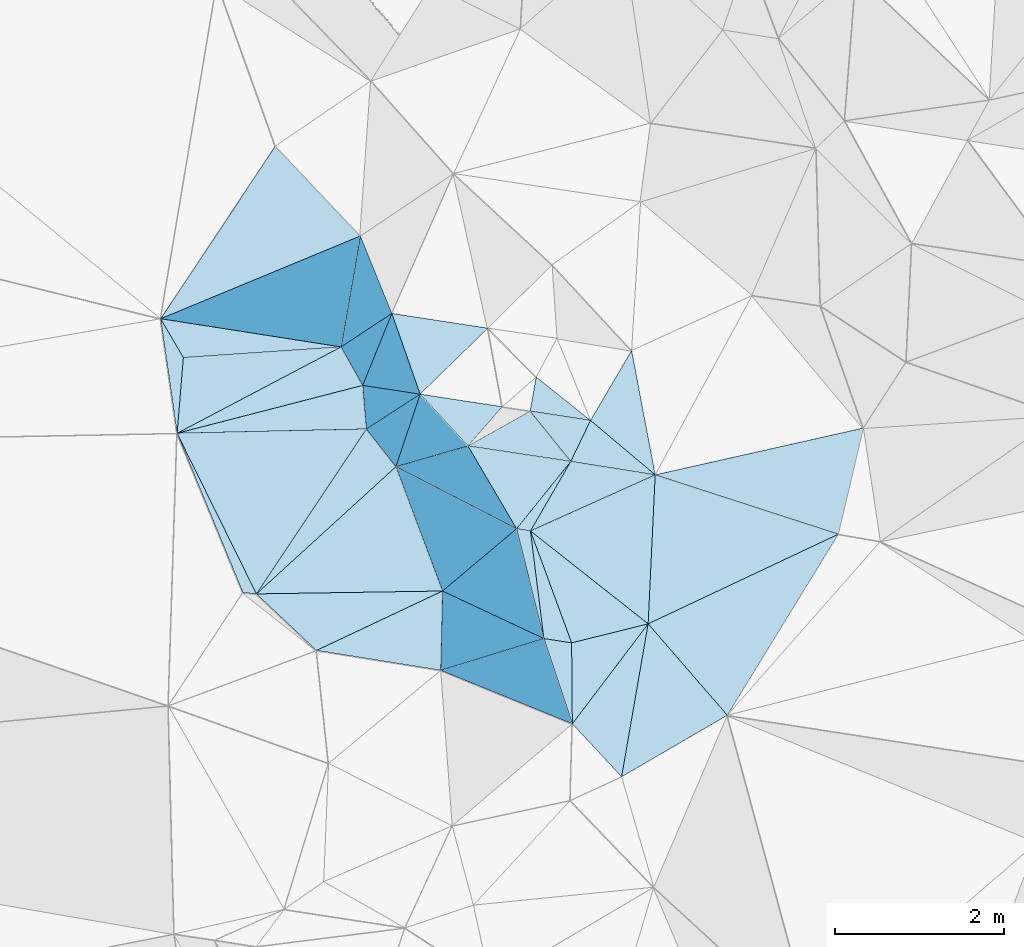
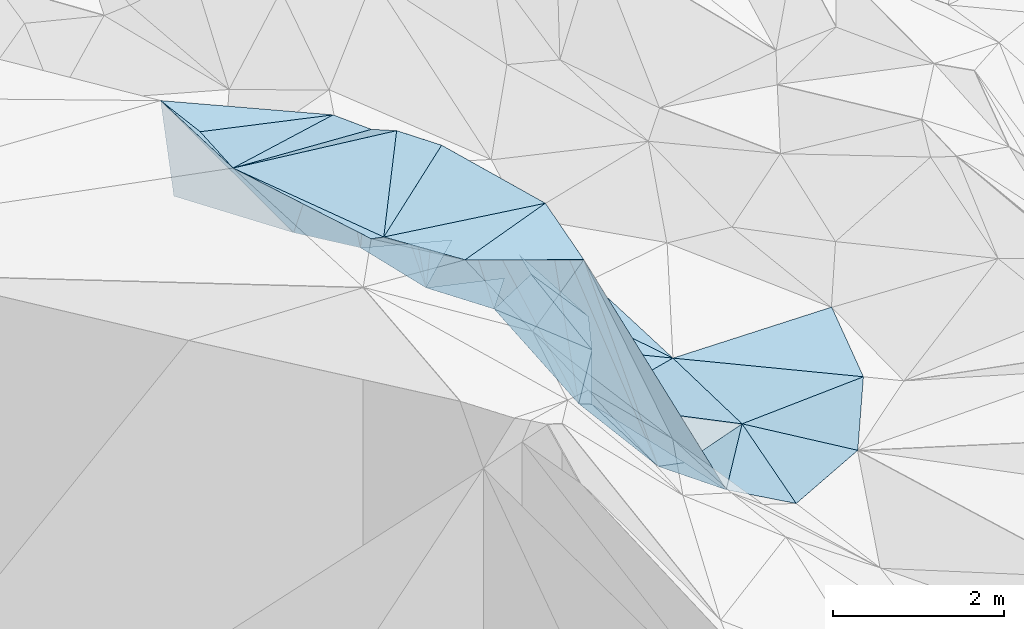
# One storey, part 134 of 275: 45 plates.
"""IFC2X3 building model written with IfcOpenShell, lengths in millimetres."""

from ifc_helpers import new_model, si_unit, frame, origin_with_axes, place, context, subcontext, project, spatial, polyline, outline, extrude, material, type_object, element, save


model = new_model("IFC2X3")

# Units and contexts
model_context = context("Model", 3, precision=1e-05, world=origin_with_axes())
body_context = subcontext(model_context, "Body", "Model", "MODEL_VIEW")
ifc_project = project(units=[si_unit("LENGTHUNIT", "METRE", prefix="MILLI"), si_unit("AREAUNIT", "SQUARE_METRE"), si_unit("VOLUMEUNIT", "CUBIC_METRE"), si_unit("MASSUNIT", "GRAM", prefix="KILO"), si_unit("TIMEUNIT", "SECOND"), si_unit("PLANEANGLEUNIT", "RADIAN"), si_unit("SOLIDANGLEUNIT", "STERADIAN"), si_unit("THERMODYNAMICTEMPERATUREUNIT", "DEGREE_CELSIUS"), si_unit("LUMINOUSINTENSITYUNIT", "LUMEN")], contexts=[model_context])

# Site, building, storey
site_placement = place(None, origin_with_axes())
site = spatial("IfcSite", under=ifc_project, at=site_placement, CompositionType="ELEMENT")
building_placement = place(site_placement, origin_with_axes())
building = spatial("IfcBuilding", under=site, at=building_placement, Name="Undefined", CompositionType="ELEMENT")
storey_placement = place(building_placement, origin_with_axes())
storey = spatial("IfcBuildingStorey", under=building, at=storey_placement, Name="Undefined", CompositionType="ELEMENT", Elevation=0.0)

# Plates
ifc_material = material()
plate_type_1 = type_object("IfcPlateType", PredefinedType="NOTDEFINED")
plate_1_placement = place(storey_placement, frame((-114521.850108405, 126878.362429934, 56799.5038081977), z_axis=(-0.121307038565296, 0.0235485674527834, -0.992335662649206), x_axis=(0.44151904645887, -0.894095826074422, -0.0751903279042392)))
element("IfcPlate", 1, at=plate_1_placement, inside=storey, type_object=plate_type_1, material=ifc_material, Name="00", context=body_context, shape_type="SweptSolid", body=[
    extrude(outline(polyline([(0.0, 0.0), (2127.93334960938, -2.6775524020195e-09), (2040.80651855469, 137.145629882813), (0.0, 0.0)])), frame((-8.85201319254618e-08, 2.18876761149539e-07, -0.5000001331573), z_axis=(0.0, 0.0, 1.0), x_axis=(1.0, 0.0, 0.0)), (0.0, 0.0, 1.0), 1.0),
])
plate_type_2 = type_object("IfcPlateType", PredefinedType="NOTDEFINED")
plate_2_placement = place(storey_placement, frame((-109859.094909564, 126545.445328037, 52769.5442182016), z_axis=(-0.291012923429786, 0.290601151879106, -0.911516565358736), x_axis=(0.927536387381028, -0.147824209733292, -0.343255375924222)))
element("IfcPlate", 2, at=plate_2_placement, inside=storey, type_object=plate_type_2, material=ifc_material, Name="00", context=body_context, shape_type="SweptSolid", body=[
    extrude(outline(polyline([(0.0, 0.0), (1077.91467285156, 5.355104804039e-09), (-283.695922851563, 915.487121582031), (0.0, 0.0)])), frame((-8.85201319254618e-08, 2.18876761149539e-07, -0.5000001331573), z_axis=(0.0, 0.0, 1.0), x_axis=(1.0, 0.0, 0.0)), (0.0, 0.0, 1.0), 1.0),
])
plate_type_3 = type_object("IfcPlateType", PredefinedType="NOTDEFINED")
plate_3_placement = place(storey_placement, frame((-111930.453018532, 126482.371384427, 56459.5051892002), z_axis=(-0.139705798158141, 0.0349493463268886, -0.989576087601312), x_axis=(0.350142722362101, -0.933066263880956, -0.0823858069335439)))
element("IfcPlate", 3, at=plate_3_placement, inside=storey, type_object=plate_type_3, material=ifc_material, Name="00", context=body_context, shape_type="SweptSolid", body=[
    extrude(outline(polyline([(0.0, 0.0), (1577.94165039063, 4.94765117764473e-10), (812.51416015625, 2090.626953125), (0.0, 0.0)])), frame((-8.85201319254618e-08, 2.18876761149539e-07, -0.5000001331573), z_axis=(0.0, 0.0, 1.0), x_axis=(1.0, 0.0, 0.0)), (0.0, 0.0, 1.0), 1.0),
])
plate_type_4 = type_object("IfcPlateType", PredefinedType="NOTDEFINED")
plate_4_placement = place(storey_placement, frame((-110341.402966534, 127141.458852054, 53659.6816474375), z_axis=(-0.635722563316343, 0.436489091255528, -0.636658539332837), x_axis=(0.667798288061703, -0.102695475755649, -0.737223904740738)))
element("IfcPlate", 4, at=plate_4_placement, inside=storey, type_object=plate_type_4, material=ifc_material, Name="00", context=body_context, shape_type="SweptSolid", body=[
    extrude(outline(polyline([(0.0, 0.0), (1071.58764648438, 4.9622030928731e-09), (1039.29907226563, 547.318420410156), (0.0, 0.0)])), frame((-8.85201319254618e-08, 2.18876761149539e-07, -0.5000001331573), z_axis=(0.0, 0.0, 1.0), x_axis=(1.0, 0.0, 0.0)), (0.0, 0.0, 1.0), 1.0),
])
plate_type_5 = type_object("IfcPlateType", PredefinedType="NOTDEFINED")
plate_5_placement = place(storey_placement, frame((-111979.063172375, 128297.743219802, 53909.8775811959), z_axis=(-0.923417799873813, -0.295596180211567, -0.244790655705111), x_axis=(0.328930213455594, -0.938165559108099, -0.107936547931854)))
element("IfcPlate", 5, at=plate_5_placement, inside=storey, type_object=plate_type_5, material=ifc_material, Name="00", context=body_context, shape_type="SweptSolid", body=[
    extrude(outline(polyline([(0.0, 0.0), (1019.11724853516, -2.5902409106493e-09), (434.591796875, 2466.82592773438), (0.0, 0.0)])), frame((-8.85201319254618e-08, 2.18876761149539e-07, -0.5000001331573), z_axis=(0.0, 0.0, 1.0), x_axis=(1.0, 0.0, 0.0)), (0.0, 0.0, 1.0), 1.0),
])
plate_type_6 = type_object("IfcPlateType", PredefinedType="NOTDEFINED")
plate_6_placement = place(storey_placement, frame((-114448.069571038, 127774.935723937, 56749.5509789215), z_axis=(-0.259511408674068, 0.355331659198126, -0.897994009300456), x_axis=(-0.453635896467046, 0.776030645035436, 0.438167674985758)))
element("IfcPlate", 6, at=plate_6_placement, inside=storey, type_object=plate_type_6, material=ifc_material, Name="00", context=body_context, shape_type="SweptSolid", body=[
    extrude(outline(polyline([(0.0, 0.0), (593.380126953125, 3.33966454491019e-09), (-964.305908203125, 1678.51538085938), (0.0, 0.0)])), frame((-8.85201319254618e-08, 2.18876761149539e-07, -0.5000001331573), z_axis=(0.0, 0.0, 1.0), x_axis=(1.0, 0.0, 0.0)), (0.0, 0.0, 1.0), 1.0),
])
plate_type_7 = type_object("IfcPlateType", PredefinedType="NOTDEFINED")
plate_7_placement = place(storey_placement, frame((-109257.106586982, 122809.654219367, 52629.5011826327), z_axis=(-0.0637456401297109, -0.0274861461955223, -0.997587592711423), x_axis=(-0.680780878414904, 0.732115498978922, 0.0233300608545309)))
element("IfcPlate", 7, at=plate_7_placement, inside=storey, type_object=plate_type_7, material=ifc_material, Name="00", context=body_context, shape_type="SweptSolid", body=[
    extrude(outline(polyline([(0.0, 0.0), (857.263061523438, -2.80988388112746e-09), (1110.86083984375, 1467.03381347656), (0.0, 0.0)])), frame((-8.85201319254618e-08, 2.18876761149539e-07, -0.5000001331573), z_axis=(0.0, 0.0, 1.0), x_axis=(1.0, 0.0, 0.0)), (0.0, 0.0, 1.0), 1.0),
])
plate_type_8 = type_object("IfcPlateType", PredefinedType="NOTDEFINED")
plate_8_placement = place(storey_placement, frame((-108942.861754222, 124621.435189749, 52559.5017801622), z_axis=(-0.0812802846684726, -0.0243985881303678, -0.996392605463056), x_axis=(0.654262607565266, -0.755463016145328, -0.0348722178603874)))
element("IfcPlate", 8, at=plate_8_placement, inside=storey, type_object=plate_type_8, material=ifc_material, Name="00", context=body_context, shape_type="SweptSolid", body=[
    extrude(outline(polyline([(0.0, 0.0), (1433.80615234375, 9.78434400167316e-09), (1160.68688964844, 1427.93762207031), (0.0, 0.0)])), frame((-8.85201319254618e-08, 2.18876761149539e-07, -0.5000001331573), z_axis=(0.0, 0.0, 1.0), x_axis=(1.0, 0.0, 0.0)), (0.0, 0.0, 1.0), 1.0),
])
plate_type_9 = type_object("IfcPlateType", PredefinedType="NOTDEFINED")
plate_9_placement = place(storey_placement, frame((-112579.564078858, 127901.012127768, 56259.5146789827), z_axis=(-0.225530950039399, -0.0841531852219587, -0.97059467956059), x_axis=(0.489667787433882, -0.871069380018801, -0.0382569358844673)))
element("IfcPlate", 9, at=plate_9_placement, inside=storey, type_object=plate_type_9, material=ifc_material, Name="00", context=body_context, shape_type="SweptSolid", body=[
    extrude(outline(polyline([(0.0, 0.0), (522.781005859375, 2.25554686039686e-10), (-80.9134216308594, 2259.12670898438), (0.0, 0.0)])), frame((-8.85201319254618e-08, 2.18876761149539e-07, -0.5000001331573), z_axis=(0.0, 0.0, 1.0), x_axis=(1.0, 0.0, 0.0)), (0.0, 0.0, 1.0), 1.0),
])
plate_type_10 = type_object("IfcPlateType", PredefinedType="NOTDEFINED")
plate_10_placement = place(storey_placement, frame((-111378.351189727, 125010.07884707, 56329.8450112842), z_axis=(-0.945673739506675, 0.09820687309003, -0.309929973518762), x_axis=(0.295409958202422, -0.138548236927378, -0.945271041891773)))
element("IfcPlate", 10, at=plate_10_placement, inside=storey, type_object=plate_type_10, material=ifc_material, Name="00", context=body_context, shape_type="SweptSolid", body=[
    extrude(outline(polyline([(0.0, 0.0), (4062.32690429688, -5.95173332840204e-09), (340.986846923828, 905.056884765625), (0.0, 0.0)])), frame((-8.85201319254618e-08, 2.18876761149539e-07, -0.5000001331573), z_axis=(0.0, 0.0, 1.0), x_axis=(1.0, 0.0, 0.0)), (0.0, 0.0, 1.0), 1.0),
])
plate_type_11 = type_object("IfcPlateType", PredefinedType="NOTDEFINED")
plate_11_placement = place(storey_placement, frame((-114717.458866926, 128235.24687473, 57009.6339244175), z_axis=(-0.681020200211253, 0.015269647448946, -0.732105405505935), x_axis=(0.45363589647522, -0.776030645011815, -0.438167675019131)))
element("IfcPlate", 11, at=plate_11_placement, inside=storey, type_object=plate_type_11, material=ifc_material, Name="00", context=body_context, shape_type="SweptSolid", body=[
    extrude(outline(polyline([(0.0, 0.0), (593.380126953125, 3.33966454491019e-09), (1233.61047363281, 633.72314453125), (0.0, 0.0)])), frame((-8.85201319254618e-08, 2.18876761149539e-07, -0.5000001331573), z_axis=(0.0, 0.0, 1.0), x_axis=(1.0, 0.0, 0.0)), (0.0, 0.0, 1.0), 1.0),
])
plate_type_12 = type_object("IfcPlateType", PredefinedType="NOTDEFINED")
plate_12_placement = place(storey_placement, frame((-112323.511332369, 127445.435536404, 56239.5641620265), z_axis=(-0.0980991100330261, -0.480250309087412, -0.871628478901518), x_axis=(0.0723526902361636, -0.876976986083281, 0.475054159118594)))
element("IfcPlate", 12, at=plate_12_placement, inside=storey, type_object=plate_type_12, material=ifc_material, Name="00", context=body_context, shape_type="SweptSolid", body=[
    extrude(outline(polyline([(0.0, 0.0), (589.406494140625, -1.12049747258425e-09), (604.506408691406, 2258.90942382813), (0.0, 0.0)])), frame((-8.85201319254618e-08, 2.18876761149539e-07, -0.5000001331573), z_axis=(0.0, 0.0, 1.0), x_axis=(1.0, 0.0, 0.0)), (0.0, 0.0, 1.0), 1.0),
])
plate_type_13 = type_object("IfcPlateType", PredefinedType="NOTDEFINED")
plate_13_placement = place(storey_placement, frame((-112870.876465291, 124306.329140083, 56469.5075005284), z_axis=(-0.140085366903416, 0.101235068453652, -0.984950532206933), x_axis=(-0.717476105655266, 0.675157175140949, 0.171437529932766)))
element("IfcPlate", 13, at=plate_13_placement, inside=storey, type_object=plate_type_13, material=ifc_material, Name="00", context=body_context, shape_type="SweptSolid", body=[
    extrude(outline(polyline([(0.0, 0.0), (991.614868164063, 4.05270839110017e-09), (-619.998779296875, 1536.00183105469), (0.0, 0.0)])), frame((-8.85201319254618e-08, 2.18876761149539e-07, -0.5000001331573), z_axis=(0.0, 0.0, 1.0), x_axis=(1.0, 0.0, 0.0)), (0.0, 0.0, 1.0), 1.0),
])
plate_type_14 = type_object("IfcPlateType", PredefinedType="NOTDEFINED")
plate_14_placement = place(storey_placement, frame((-110268.563737391, 127545.279623098, 53669.6623689622), z_axis=(-0.722794316118149, 0.147120264123154, -0.675221448468301), x_axis=(0.559990311342113, -0.44784885664892, -0.697023853825118)))
element("IfcPlate", 14, at=plate_14_placement, inside=storey, type_object=plate_type_14, material=ifc_material, Name="00", context=body_context, shape_type="SweptSolid", body=[
    extrude(outline(polyline([(0.0, 0.0), (1147.73693847656, -4.23460733145475e-09), (147.072036743164, 383.366424560547), (0.0, 0.0)])), frame((-8.85201319254618e-08, 2.18876761149539e-07, -0.5000001331573), z_axis=(0.0, 0.0, 1.0), x_axis=(1.0, 0.0, 0.0)), (0.0, 0.0, 1.0), 1.0),
])
plate_type_15 = type_object("IfcPlateType", PredefinedType="NOTDEFINED")
plate_15_placement = place(storey_placement, frame((-111400.129694698, 124070.994959587, 56099.5247987952), z_axis=(-0.201068046663525, 0.23748534042021, -0.950353804483578), x_axis=(-0.958308527772369, 0.153380149635556, 0.241079437730657)))
element("IfcPlate", 15, at=plate_15_placement, inside=storey, type_object=plate_type_15, material=ifc_material, Name="00", context=body_context, shape_type="SweptSolid", body=[
    extrude(outline(polyline([(0.0, 0.0), (1534.76379394531, 2.8521753847599e-09), (178.268463134766, 950.589477539063), (0.0, 0.0)])), frame((-8.85201319254618e-08, 2.18876761149539e-07, -0.5000001331573), z_axis=(0.0, 0.0, 1.0), x_axis=(1.0, 0.0, 0.0)), (0.0, 0.0, 1.0), 1.0),
])
plate_type_16 = type_object("IfcPlateType", PredefinedType="NOTDEFINED")
plate_16_placement = place(storey_placement, frame((-109859.139083146, 126545.630324462, 52769.6760554799), z_axis=(-0.379364239505798, 0.660593294165149, -0.647842012753283), x_axis=(-0.798456375106251, 0.120040267748708, 0.589964194821181)))
element("IfcPlate", 16, at=plate_16_placement, inside=storey, type_object=plate_type_16, material=ifc_material, Name="00", context=body_context, shape_type="SweptSolid", body=[
    extrude(outline(polyline([(0.0, 0.0), (1525.51635742188, -9.12405084818602e-09), (981.5693359375, 645.152465820313), (0.0, 0.0)])), frame((-8.85201319254618e-08, 2.18876761149539e-07, -0.5000001331573), z_axis=(0.0, 0.0, 1.0), x_axis=(1.0, 0.0, 0.0)), (0.0, 0.0, 1.0), 1.0),
])
plate_type_17 = type_object("IfcPlateType", PredefinedType="NOTDEFINED")
plate_17_placement = place(storey_placement, frame((-108942.889292323, 124621.405871983, 52559.5063906169), z_axis=(-0.136372291229937, -0.0830463125288373, -0.987170658072889), x_axis=(-0.783683359827885, 0.618611053457249, 0.056220601823441)))
element("IfcPlate", 17, at=plate_17_placement, inside=storey, type_object=plate_type_17, material=ifc_material, Name="00", context=body_context, shape_type="SweptSolid", body=[
    extrude(outline(polyline([(0.0, 0.0), (1778.70739746094, -4.39467839896679e-09), (1016.97448730469, 1453.22497558594), (0.0, 0.0)])), frame((-8.85201319254618e-08, 2.18876761149539e-07, -0.5000001331573), z_axis=(0.0, 0.0, 1.0), x_axis=(1.0, 0.0, 0.0)), (0.0, 0.0, 1.0), 1.0),
])
plate_type_18 = type_object("IfcPlateType", PredefinedType="NOTDEFINED")
plate_18_placement = place(storey_placement, frame((-111643.456316188, 127341.82138771, 53799.5063578451), z_axis=(-0.146618458707786, 0.0621763664324773, -0.987237117932368), x_axis=(-0.328930213458411, 0.938165559107429, 0.107936547929095)))
element("IfcPlate", 18, at=plate_18_placement, inside=storey, type_object=plate_type_18, material=ifc_material, Name="00", context=body_context, shape_type="SweptSolid", body=[
    extrude(outline(polyline([(0.0, 0.0), (1019.11724853516, -2.5902409106493e-09), (461.379669189453, 1023.04876708984), (0.0, 0.0)])), frame((-8.85201319254618e-08, 2.18876761149539e-07, -0.5000001331573), z_axis=(0.0, 0.0, 1.0), x_axis=(1.0, 0.0, 0.0)), (0.0, 0.0, 1.0), 1.0),
])
plate_type_19 = type_object("IfcPlateType", PredefinedType="NOTDEFINED")
plate_19_placement = place(storey_placement, frame((-110336.800019739, 125721.837030044, 52659.5050557303), z_axis=(-0.0710396962540525, 0.123164259125576, -0.98984035421384), x_axis=(0.341853733513329, -0.929242481385502, -0.140158608981087)))
element("IfcPlate", 19, at=plate_19_placement, inside=storey, type_object=plate_type_19, material=ifc_material, Name="00", context=body_context, shape_type="SweptSolid", body=[
    extrude(outline(polyline([(0.0, 0.0), (1426.95483398438, -3.02679836750031e-09), (1262.54870605469, 290.982208251953), (0.0, 0.0)])), frame((-8.85201319254618e-08, 2.18876761149539e-07, -0.5000001331573), z_axis=(0.0, 0.0, 1.0), x_axis=(1.0, 0.0, 0.0)), (0.0, 0.0, 1.0), 1.0),
])
plate_type_20 = type_object("IfcPlateType", PredefinedType="NOTDEFINED")
plate_20_placement = place(storey_placement, frame((-111643.42934388, 127341.852209925, 53799.5059927018), z_axis=(-0.0926727414374648, 0.123821853597178, -0.987967566049728), x_axis=(0.982356975897781, -0.150504899604535, -0.11100922078816)))
element("IfcPlate", 20, at=plate_20_placement, inside=storey, type_object=plate_type_20, material=ifc_material, Name="00", context=body_context, shape_type="SweptSolid", body=[
    extrude(outline(polyline([(0.0, 0.0), (990.90869140625, -4.19095158576965e-09), (663.128723144531, 523.603210449219), (0.0, 0.0)])), frame((-8.85201319254618e-08, 2.18876761149539e-07, -0.5000001331573), z_axis=(0.0, 0.0, 1.0), x_axis=(1.0, 0.0, 0.0)), (0.0, 0.0, 1.0), 1.0),
])
plate_type_21 = type_object("IfcPlateType", PredefinedType="NOTDEFINED")
plate_21_placement = place(storey_placement, frame((-110178.298886365, 124447.106660259, 52489.8662593176), z_axis=(-0.944718850219206, -0.189699157723122, -0.267433213344266), x_axis=(-0.295409958209512, 0.138548236927643, 0.945271041889519)))
element("IfcPlate", 21, at=plate_21_placement, inside=storey, type_object=plate_type_21, material=ifc_material, Name="00", context=body_context, shape_type="SweptSolid", body=[
    extrude(outline(polyline([(0.0, 0.0), (4062.32690429688, -5.95173332840204e-09), (483.639068603516, 1268.77624511719), (0.0, 0.0)])), frame((-8.85201319254618e-08, 2.18876761149539e-07, -0.5000001331573), z_axis=(0.0, 0.0, 1.0), x_axis=(1.0, 0.0, 0.0)), (0.0, 0.0, 1.0), 1.0),
])
plate_type_22 = type_object("IfcPlateType", PredefinedType="NOTDEFINED")
plate_22_placement = place(storey_placement, frame((-111643.750130212, 127341.480884945, 53799.8603959078), z_axis=(-0.734247811252084, -0.618828208437225, -0.2791626767924), x_axis=(0.670325392126611, -0.725941516538806, -0.153859621849412)))
element("IfcPlate", 22, at=plate_22_placement, inside=storey, type_object=plate_type_22, material=ifc_material, Name="00", context=body_context, shape_type="SweptSolid", body=[
    extrude(outline(polyline([(0.0, 0.0), (844.926025390625, 3.63797880709171e-11), (22.2504692077637, 2810.0009765625), (0.0, 0.0)])), frame((-8.85201319254618e-08, 2.18876761149539e-07, -0.5000001331573), z_axis=(0.0, 0.0, 1.0), x_axis=(1.0, 0.0, 0.0)), (0.0, 0.0, 1.0), 1.0),
])
plate_type_23 = type_object("IfcPlateType", PredefinedType="NOTDEFINED")
plate_23_placement = place(storey_placement, frame((-111930.770607684, 126482.067808786, 56459.8657320063), z_axis=(-0.774915920413278, -0.572206223229573, -0.268487158701101), x_axis=(-0.614040945642122, 0.782240756268143, 0.105133801928645)))
element("IfcPlate", 23, at=plate_23_placement, inside=storey, type_object=plate_type_23, material=ifc_material, Name="00", context=body_context, shape_type="SweptSolid", body=[
    extrude(outline(polyline([(0.0, 0.0), (570.701293945313, -1.0113581083715e-09), (216.400405883789, 2801.744140625), (0.0, 0.0)])), frame((-8.85201319254618e-08, 2.18876761149539e-07, -0.5000001331573), z_axis=(0.0, 0.0, 1.0), x_axis=(1.0, 0.0, 0.0)), (0.0, 0.0, 1.0), 1.0),
])
plate_type_24 = type_object("IfcPlateType", PredefinedType="NOTDEFINED")
plate_24_placement = place(storey_placement, frame((-111077.250955025, 126728.64750217, 53669.6250467797), z_axis=(-0.486677084359222, 0.448172769174723, -0.749857709522192), x_axis=(0.798456375101053, -0.120040267752641, -0.589964194827415)))
element("IfcPlate", 24, at=plate_24_placement, inside=storey, type_object=plate_type_24, material=ifc_material, Name="00", context=body_context, shape_type="SweptSolid", body=[
    extrude(outline(polyline([(0.0, 0.0), (1525.51635742188, -9.12405084818602e-09), (1143.875, 952.339172363281), (0.0, 0.0)])), frame((-8.85201319254618e-08, 2.18876761149539e-07, -0.5000001331573), z_axis=(0.0, 0.0, 1.0), x_axis=(1.0, 0.0, 0.0)), (0.0, 0.0, 1.0), 1.0),
])
plate_type_25 = type_object("IfcPlateType", PredefinedType="NOTDEFINED")
plate_25_placement = place(storey_placement, frame((-112280.883974411, 126928.793847425, 56519.5046642092), z_axis=(-0.133673484917315, 0.028210058459547, -0.990623839826081), x_axis=(0.614040945660217, -0.782240756255343, -0.105133801918206)))
element("IfcPlate", 25, at=plate_25_placement, inside=storey, type_object=plate_type_25, material=ifc_material, Name="00", context=body_context, shape_type="SweptSolid", body=[
    extrude(outline(polyline([(0.0, 0.0), (570.701293945313, -1.0113581083715e-09), (715.961181640625, 2238.25805664063), (0.0, 0.0)])), frame((-8.85201319254618e-08, 2.18876761149539e-07, -0.5000001331573), z_axis=(0.0, 0.0, 1.0), x_axis=(1.0, 0.0, 0.0)), (0.0, 0.0, 1.0), 1.0),
])
plate_type_26 = type_object("IfcPlateType", PredefinedType="NOTDEFINED")
plate_26_placement = place(storey_placement, frame((-112351.89417865, 129215.274136249, 53699.8546840224), z_axis=(-0.8614232976461, -0.416542453952207, -0.290589549584964), x_axis=(0.368268814668738, -0.906287971254666, 0.207413098191951)))
element("IfcPlate", 26, at=plate_26_placement, inside=storey, type_object=plate_type_26, material=ifc_material, Name="00", context=body_context, shape_type="SweptSolid", body=[
    extrude(outline(polyline([(0.0, 0.0), (1012.47222900391, -2.85945134237409e-09), (1638.26721191406, 2376.84252929688), (0.0, 0.0)])), frame((-8.85201319254618e-08, 2.18876761149539e-07, -0.5000001331573), z_axis=(0.0, 0.0, 1.0), x_axis=(1.0, 0.0, 0.0)), (0.0, 0.0, 1.0), 1.0),
])
plate_type_27 = type_object("IfcPlateType", PredefinedType="NOTDEFINED")
plate_27_placement = place(storey_placement, frame((-110177.886173508, 124447.104483378, 52489.5131151444), z_axis=(-0.119159959116354, -0.194046015446248, -0.973728426222026), x_axis=(0.98401137168131, -0.15383212957456, -0.0897624437747916)))
element("IfcPlate", 27, at=plate_27_placement, inside=storey, type_object=plate_type_27, material=ifc_material, Name="00", context=body_context, shape_type="SweptSolid", body=[
    extrude(outline(polyline([(0.0, 0.0), (334.215484619141, 7.27595761418343e-10), (472.748870849609, 967.320251464844), (0.0, 0.0)])), frame((-8.85201319254618e-08, 2.18876761149539e-07, -0.5000001331573), z_axis=(0.0, 0.0, 1.0), x_axis=(1.0, 0.0, 0.0)), (0.0, 0.0, 1.0), 1.0),
])
plate_type_28 = type_object("IfcPlateType", PredefinedType="NOTDEFINED")
plate_28_placement = place(storey_placement, frame((-114717.439315334, 128235.000600351, 57009.699914058), z_axis=(-0.641917734288737, -0.477278549883554, -0.60012232771883), x_axis=(0.345161671960033, 0.519016462132467, -0.781975275980802)))
element("IfcPlate", 28, at=plate_28_placement, inside=storey, type_object=plate_type_28, material=ifc_material, Name="00", context=body_context, shape_type="SweptSolid", body=[
    extrude(outline(polyline([(0.0, 0.0), (3938.74340820313, 2.35741026699543e-08), (3913.63403320313, 1482.15026855469), (0.0, 0.0)])), frame((-8.85201319254618e-08, 2.18876761149539e-07, -0.5000001331573), z_axis=(0.0, 0.0, 1.0), x_axis=(1.0, 0.0, 0.0)), (0.0, 0.0, 1.0), 1.0),
])
plate_type_29 = type_object("IfcPlateType", PredefinedType="NOTDEFINED")
plate_29_placement = place(storey_placement, frame((-112323.933802716, 127445.568051952, 56239.8731350912), z_axis=(-0.94304042839982, -0.215221347440358, -0.253681930790194), x_axis=(0.268261763123369, -0.040978267935865, -0.962474107705198)))
element("IfcPlate", 29, at=plate_29_placement, inside=storey, type_object=plate_type_29, material=ifc_material, Name="00", context=body_context, shape_type="SweptSolid", body=[
    extrude(outline(polyline([(0.0, 0.0), (2535.13305664063, 5.96628524363041e-09), (-236.871185302734, 539.714782714844), (0.0, 0.0)])), frame((-8.85201319254618e-08, 2.18876761149539e-07, -0.5000001331573), z_axis=(0.0, 0.0, 1.0), x_axis=(1.0, 0.0, 0.0)), (0.0, 0.0, 1.0), 1.0),
])
plate_type_30 = type_object("IfcPlateType", PredefinedType="NOTDEFINED")
plate_30_placement = place(storey_placement, frame((-108859.373528594, 126386.007624054, 52399.5583601578), z_axis=(-0.458374588770808, 0.0989566597498415, -0.88323287747929), x_axis=(-0.692532329268012, 0.583094168762865, 0.424735403837924)))
element("IfcPlate", 30, at=plate_30_placement, inside=storey, type_object=plate_type_30, material=ifc_material, Name="00", context=body_context, shape_type="SweptSolid", body=[
    extrude(outline(polyline([(0.0, 0.0), (1106.5712890625, 2.75758793577552e-09), (1183.92736816406, 970.369018554688), (0.0, 0.0)])), frame((-8.85201319254618e-08, 2.18876761149539e-07, -0.5000001331573), z_axis=(0.0, 0.0, 1.0), x_axis=(1.0, 0.0, 0.0)), (0.0, 0.0, 1.0), 1.0),
])
plate_type_31 = type_object("IfcPlateType", PredefinedType="NOTDEFINED")
plate_31_placement = place(storey_placement, frame((-114521.915153227, 126878.334038436, 56799.5163221069), z_axis=(-0.25142342731532, -0.0332413375278233, -0.967306194375069), x_axis=(0.0819792816711976, 0.995087273861566, -0.0555041870081072)))
element("IfcPlate", 31, at=plate_31_placement, inside=storey, type_object=plate_type_31, material=ifc_material, Name="00", context=body_context, shape_type="SweptSolid", body=[
    extrude(outline(polyline([(0.0, 0.0), (900.832946777344, -3.11410985887051e-09), (1206.88305664063, 1911.44799804688), (0.0, 0.0)])), frame((-8.85201319254618e-08, 2.18876761149539e-07, -0.5000001331573), z_axis=(0.0, 0.0, 1.0), x_axis=(1.0, 0.0, 0.0)), (0.0, 0.0, 1.0), 1.0),
])
plate_type_32 = type_object("IfcPlateType", PredefinedType="NOTDEFINED")
plate_32_placement = place(storey_placement, frame((-109841.121670495, 123437.110742828, 52649.8334548488), z_axis=(-0.877281706648582, -0.345628755725491, -0.333042895728764), x_axis=(-0.40621886415765, 0.165054623873229, 0.898745350775477)))
element("IfcPlate", 32, at=plate_32_placement, inside=storey, type_object=plate_type_32, material=ifc_material, Name="00", context=body_context, shape_type="SweptSolid", body=[
    extrude(outline(polyline([(0.0, 0.0), (3838.6845703125, -1.41153577715158e-09), (159.846420288086, 1064.72961425781), (0.0, 0.0)])), frame((-8.85201319254618e-08, 2.18876761149539e-07, -0.5000001331573), z_axis=(0.0, 0.0, 1.0), x_axis=(1.0, 0.0, 0.0)), (0.0, 0.0, 1.0), 1.0),
])
plate_type_33 = type_object("IfcPlateType", PredefinedType="NOTDEFINED")
plate_33_placement = place(storey_placement, frame((-110336.885646446, 125721.908072546, 52659.533356037), z_axis=(-0.242304236042023, 0.26524156091734, -0.933239289549162), x_axis=(-0.946222425882143, 0.147924520791413, 0.287717668742021)))
element("IfcPlate", 33, at=plate_33_placement, inside=storey, type_object=plate_type_33, material=ifc_material, Name="00", context=body_context, shape_type="SweptSolid", body=[
    extrude(outline(polyline([(0.0, 0.0), (173.781478881836, -8.29459168016911e-10), (-298.650939941406, 910.718200683594), (0.0, 0.0)])), frame((-8.85201319254618e-08, 2.18876761149539e-07, -0.5000001331573), z_axis=(0.0, 0.0, 1.0), x_axis=(1.0, 0.0, 0.0)), (0.0, 0.0, 1.0), 1.0),
])
plate_type_34 = type_object("IfcPlateType", PredefinedType="NOTDEFINED")
plate_34_placement = place(storey_placement, frame((-109840.605780494, 123437.18814866, 52649.515281789), z_axis=(0.15450270912394, -0.1908241947753, -0.969389003218894), x_axis=(-0.00846472529407544, 0.980878862349577, -0.194435094109825)))
element("IfcPlate", 34, at=plate_34_placement, inside=storey, type_object=plate_type_34, material=ifc_material, Name="00", context=body_context, shape_type="SweptSolid", body=[
    extrude(outline(polyline([(0.0, 0.0), (977.189819335938, -3.65253072232008e-09), (1171.42028808594, 918.844116210938), (0.0, 0.0)])), frame((-8.85201319254618e-08, 2.18876761149539e-07, -0.5000001331573), z_axis=(0.0, 0.0, 1.0), x_axis=(1.0, 0.0, 0.0)), (0.0, 0.0, 1.0), 1.0),
])
plate_type_35 = type_object("IfcPlateType", PredefinedType="NOTDEFINED")
plate_35_placement = place(storey_placement, frame((-113582.328598086, 124975.785385418, 56639.5039835029), z_axis=(-0.124438651382767, 0.0219725514097025, -0.991983986275276), x_axis=(-0.441519046428469, 0.894095826089644, 0.075190327901746)))
element("IfcPlate", 35, at=plate_35_placement, inside=storey, type_object=plate_type_35, material=ifc_material, Name="00", context=body_context, shape_type="SweptSolid", body=[
    extrude(outline(polyline([(0.0, 0.0), (2127.93334960938, -2.6775524020195e-09), (1162.53649902344, 2042.28039550781), (0.0, 0.0)])), frame((-8.85201319254618e-08, 2.18876761149539e-07, -0.5000001331573), z_axis=(0.0, 0.0, 1.0), x_axis=(1.0, 0.0, 0.0)), (0.0, 0.0, 1.0), 1.0),
])
plate_type_36 = type_object("IfcPlateType", PredefinedType="NOTDEFINED")
plate_36_placement = place(storey_placement, frame((-108004.857193589, 123538.176447231, 52509.5222752578), z_axis=(-0.243627446781072, -0.166890148927195, -0.955402190371152), x_axis=(-0.654262607566435, 0.755463016144048, 0.0348722178662014)))
element("IfcPlate", 36, at=plate_36_placement, inside=storey, type_object=plate_type_36, material=ifc_material, Name="00", context=body_context, shape_type="SweptSolid", body=[
    extrude(outline(polyline([(0.0, 0.0), (1433.80615234375, 9.78434400167316e-09), (735.245849609375, 2508.64770507813), (0.0, 0.0)])), frame((-8.85201319254618e-08, 2.18876761149539e-07, -0.5000001331573), z_axis=(0.0, 0.0, 1.0), x_axis=(1.0, 0.0, 0.0)), (0.0, 0.0, 1.0), 1.0),
])
plate_type_37 = type_object("IfcPlateType", PredefinedType="NOTDEFINED")
plate_37_placement = place(storey_placement, frame((-110336.731723088, 125721.861630542, 52659.5085500044), z_axis=(0.0655435993520684, 0.172356978528251, -0.982851519069176), x_axis=(0.783683359831807, -0.618611053452612, -0.0562206018197983)))
element("IfcPlate", 37, at=plate_37_placement, inside=storey, type_object=plate_type_37, material=ifc_material, Name="00", context=body_context, shape_type="SweptSolid", body=[
    extrude(outline(polyline([(0.0, 0.0), (1778.70739746094, -4.39467839896679e-09), (1213.802734375, 750.255126953125), (0.0, 0.0)])), frame((-8.85201319254618e-08, 2.18876761149539e-07, -0.5000001331573), z_axis=(0.0, 0.0, 1.0), x_axis=(1.0, 0.0, 0.0)), (0.0, 0.0, 1.0), 1.0),
])
plate_type_38 = type_object("IfcPlateType", PredefinedType="NOTDEFINED")
plate_38_placement = place(storey_placement, frame((-106689.818762889, 125683.214929549, 51799.5178556634), z_axis=(-0.217728896893462, 0.151101009173695, -0.96424198855072), x_axis=(-0.920012043411374, 0.298050828788307, 0.254447525900001)))
element("IfcPlate", 38, at=plate_38_placement, inside=storey, type_object=plate_type_38, material=ifc_material, Name="00", context=body_context, shape_type="SweptSolid", body=[
    extrude(outline(polyline([(0.0, 0.0), (2358.05004882813, 1.4042598195374e-08), (134.687561035156, 1291.53369140625), (0.0, 0.0)])), frame((-8.85201319254618e-08, 2.18876761149539e-07, -0.5000001331573), z_axis=(0.0, 0.0, 1.0), x_axis=(1.0, 0.0, 0.0)), (0.0, 0.0, 1.0), 1.0),
])
plate_type_39 = type_object("IfcPlateType", PredefinedType="NOTDEFINED")
plate_39_placement = place(storey_placement, frame((-110501.338570711, 125747.528556137, 52709.5217011875), z_axis=(-0.276298775207744, 0.0931283538663769, -0.956549055994955), x_axis=(0.946222425893068, -0.147924520667894, -0.287717668769598)))
element("IfcPlate", 39, at=plate_39_placement, inside=storey, type_object=plate_type_39, material=ifc_material, Name="00", context=body_context, shape_type="SweptSolid", body=[
    extrude(outline(polyline([(0.0, 0.0), (173.781478881836, -8.29459168016911e-10), (561.624877929688, 1236.23522949219), (0.0, 0.0)])), frame((-8.85201319254618e-08, 2.18876761149539e-07, -0.5000001331573), z_axis=(0.0, 0.0, 1.0), x_axis=(1.0, 0.0, 0.0)), (0.0, 0.0, 1.0), 1.0),
])
plate_type_40 = type_object("IfcPlateType", PredefinedType="NOTDEFINED")
plate_40_placement = place(storey_placement, frame((-108859.285856571, 126386.119114416, 52399.5482448706), z_axis=(-0.283038563227879, 0.32193680993344, -0.903463259981156), x_axis=(-0.927536387378734, 0.147824209742342, 0.343255375926525)))
element("IfcPlate", 40, at=plate_40_placement, inside=storey, type_object=plate_type_40, material=ifc_material, Name="00", context=body_context, shape_type="SweptSolid", body=[
    extrude(outline(polyline([(0.0, 0.0), (1077.91467285156, 5.355104804039e-09), (967.516296386719, 537.040222167969), (0.0, 0.0)])), frame((-8.85201319254618e-08, 2.18876761149539e-07, -0.5000001331573), z_axis=(0.0, 0.0, 1.0), x_axis=(1.0, 0.0, 0.0)), (0.0, 0.0, 1.0), 1.0),
])
plate_type_41 = type_object("IfcPlateType", PredefinedType="NOTDEFINED")
plate_41_placement = place(storey_placement, frame((-108859.288206681, 126385.921674223, 52399.5225128046), z_axis=(-0.287735647139346, -0.072944679583452, -0.954927887898227), x_axis=(0.920012043414583, -0.298050828783714, -0.25444752589378)))
element("IfcPlate", 41, at=plate_41_placement, inside=storey, type_object=plate_type_41, material=ifc_material, Name="00", context=body_context, shape_type="SweptSolid", body=[
    extrude(outline(polyline([(0.0, 0.0), (2358.05004882813, 1.4042598195374e-08), (408.218658447266, 1726.11047363281), (0.0, 0.0)])), frame((-8.85201319254618e-08, 2.18876761149539e-07, -0.5000001331573), z_axis=(0.0, 0.0, 1.0), x_axis=(1.0, 0.0, 0.0)), (0.0, 0.0, 1.0), 1.0),
])
plate_type_42 = type_object("IfcPlateType", PredefinedType="NOTDEFINED")
plate_42_placement = place(storey_placement, frame((-110501.661018013, 125747.360028899, 52709.8483432451), z_axis=(-0.921157611500796, -0.243921621230684, -0.303267039868073), x_axis=(-0.35030356328261, 0.180122699906419, 0.919153538060932)))
element("IfcPlate", 42, at=plate_42_placement, inside=storey, type_object=plate_type_42, material=ifc_material, Name="00", context=body_context, shape_type="SweptSolid", body=[
    extrude(outline(polyline([(0.0, 0.0), (4079.84057617188, 1.98051566258073e-08), (1260.78454589844, 791.08935546875), (0.0, 0.0)])), frame((-8.85201319254618e-08, 2.18876761149539e-07, -0.5000001331573), z_axis=(0.0, 0.0, 1.0), x_axis=(1.0, 0.0, 0.0)), (0.0, 0.0, 1.0), 1.0),
])
plate_type_43 = type_object("IfcPlateType", PredefinedType="NOTDEFINED")
plate_43_placement = place(storey_placement, frame((-111930.836065339, 126482.196468094, 56459.8582217767), z_axis=(-0.905800357098207, -0.314878256570676, -0.283509076785512), x_axis=(0.35030356328424, -0.180122699909069, -0.919153538059791)))
element("IfcPlate", 43, at=plate_43_placement, inside=storey, type_object=plate_type_43, material=ifc_material, Name="00", context=body_context, shape_type="SweptSolid", body=[
    extrude(outline(polyline([(0.0, 0.0), (4079.84057617188, 1.98051566258073e-08), (578.233337402344, 1468.17785644531), (0.0, 0.0)])), frame((-8.85201319254618e-08, 2.18876761149539e-07, -0.5000001331573), z_axis=(0.0, 0.0, 1.0), x_axis=(1.0, 0.0, 0.0)), (0.0, 0.0, 1.0), 1.0),
])
plate_type_44 = type_object("IfcPlateType", PredefinedType="NOTDEFINED")
plate_44_placement = place(storey_placement, frame((-112579.59720848, 127900.634169108, 56259.7713160639), z_axis=(-0.291780517281275, -0.840073140843784, -0.457319634137801), x_axis=(-0.933505758012646, 0.145936502647407, 0.327520284795124)))
element("IfcPlate", 44, at=plate_44_placement, inside=storey, type_object=plate_type_44, material=ifc_material, Name="00", context=body_context, shape_type="SweptSolid", body=[
    extrude(outline(polyline([(0.0, 0.0), (2289.9345703125, -9.22591425478458e-09), (-859.456909179688, 2755.83642578125), (0.0, 0.0)])), frame((-8.85201319254618e-08, 2.18876761149539e-07, -0.5000001331573), z_axis=(0.0, 0.0, 1.0), x_axis=(1.0, 0.0, 0.0)), (0.0, 0.0, 1.0), 1.0),
])
plate_type_45 = type_object("IfcPlateType", PredefinedType="NOTDEFINED")
plate_45_placement = place(storey_placement, frame((-112323.881855103, 127445.44621991, 56239.8539560159), z_axis=(-0.83912838831394, -0.45888606614881, -0.292039597007186), x_axis=(-0.48966778743864, 0.871069380015169, 0.0382569359062643)))
element("IfcPlate", 45, at=plate_45_placement, inside=storey, type_object=plate_type_45, material=ifc_material, Name="00", context=body_context, shape_type="SweptSolid", body=[
    extrude(outline(polyline([(0.0, 0.0), (522.781005859375, 2.25554686039686e-10), (484.332794189453, 2457.5439453125), (0.0, 0.0)])), frame((-8.85201319254618e-08, 2.18876761149539e-07, -0.5000001331573), z_axis=(0.0, 0.0, 1.0), x_axis=(1.0, 0.0, 0.0)), (0.0, 0.0, 1.0), 1.0),
])

save(model, "model.ifc")
